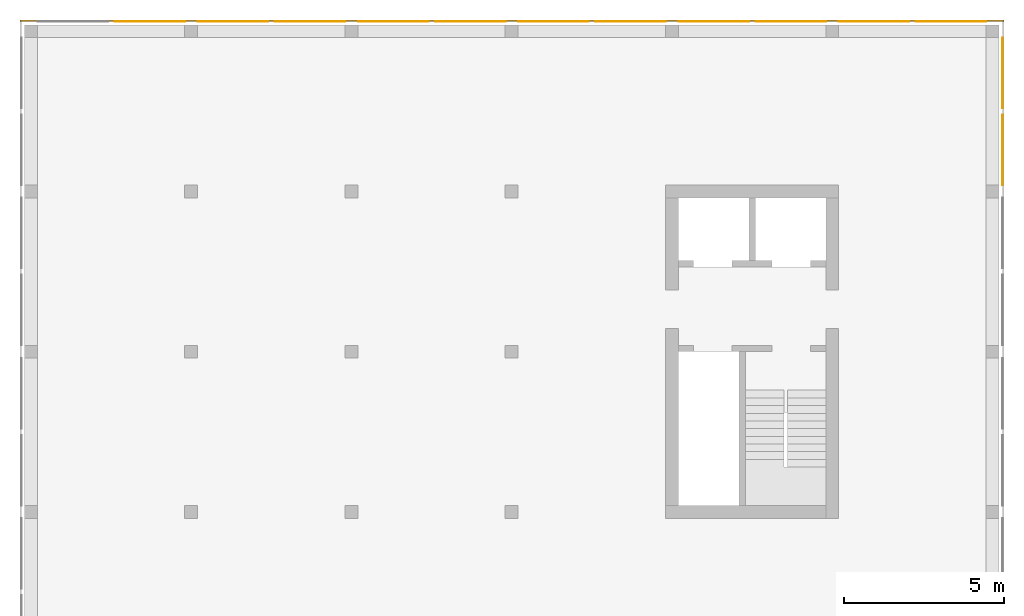
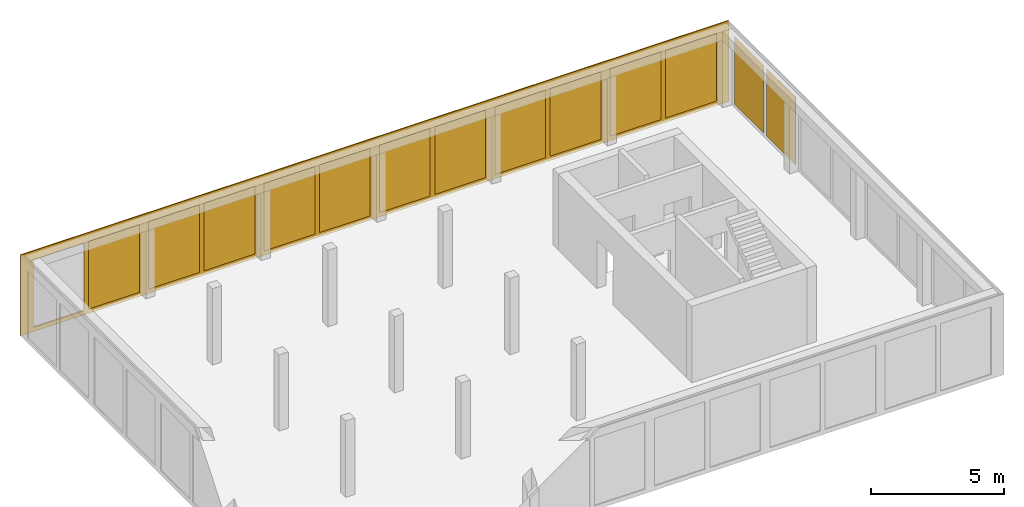
# One storey, part 4 of 4: 14 curtain walls.
"""IFC2X3 building model written with IfcOpenShell, lengths in metres."""

from ifc_helpers import new_model, entity, si_unit, converted_unit, frame, origin, place, context, subcontext, project, spatial, faceted_brep, material, element, save


model = new_model("IFC2X3")

# Units and contexts
model_context = context("Model", 3, precision=1e-05, world=origin())
body_context = subcontext(model_context, "Body", "Model", "MODEL_VIEW")
ifc_project = project(units=[si_unit("LENGTHUNIT", "METRE"), si_unit("AREAUNIT", "SQUARE_METRE"), si_unit("VOLUMEUNIT", "CUBIC_METRE"), si_unit("MASSUNIT", "GRAM", prefix="KILO"), converted_unit("PLANEANGLEUNIT", "DEGREE", entity("IfcPlaneAngleMeasure", 0.0174532925199433), si_unit("PLANEANGLEUNIT", "RADIAN"), dimensions=[0, 0, 0, 0, 0, 0, 0])], contexts=[model_context])

# Site, building, storey
site_placement = place(None, origin())
site = spatial("IfcSite", under=ifc_project, at=site_placement, CompositionType="ELEMENT")
building_placement = place(site_placement, origin())
building = spatial("IfcBuilding", under=site, at=building_placement, CompositionType="ELEMENT")
storey_placement = place(building_placement, frame((0.0, 0.0, 4.9)))
storey = spatial("IfcBuildingStorey", under=building, at=storey_placement, Name="1. Obergeschoss", CompositionType="ELEMENT", Elevation=4.9)

# Curtain walls
ifc_material_1 = material(Name="ALU")
curtain_wall_1_placement = place(storey_placement, frame((-0.139330706017223, 20.5, -0.2)))
element("IfcCurtainWall", 1, at=curtain_wall_1_placement, inside=storey, material=ifc_material_1, Name="Profil SN standard", context=body_context, shape_type="Brep", body=[
    faceted_brep([(0.0, 0.05, 3.7), (30.7, 0.05, 3.7), (30.7, 0.0, 3.7), (0.0, 0.0, 3.7), (30.7, 0.05, 0.0), (0.0, 0.05, 0.0), (0.0, 0.0, 0.0), (30.7, 0.0, 0.0), (27.95, 0.0, 0.2), (27.95, 0.0, 3.3), (27.95, 0.05, 3.3), (27.95, 0.05, 0.2), (27.75, 0.05, 0.2), (27.75, 0.05, 3.3), (27.75, 0.0, 3.3), (27.75, 0.0, 0.2), (22.95, 0.0, 0.2), (22.95, 0.0, 3.3), (22.95, 0.05, 3.3), (22.95, 0.05, 0.2), (22.75, 0.05, 0.2), (22.75, 0.05, 3.3), (22.75, 0.0, 3.3), (22.75, 0.0, 0.2), (17.75, 0.05, 0.200000000000001), (17.75, 0.05, 3.3), (17.75, 0.0, 3.3), (17.75, 0.0, 0.200000000000001), (17.95, 0.0, 0.200000000000001), (17.95, 0.0, 3.3), (17.95, 0.05, 3.3), (17.95, 0.05, 0.200000000000001), (25.15, 0.0, 0.200000000000001), (25.15, 0.05, 0.200000000000001), (25.15, 0.05, 3.3), (25.15, 0.0, 3.3), (25.55, 0.05, 0.200000000000001), (25.55, 0.0, 0.200000000000001), (25.55, 0.0, 3.3), (25.55, 0.05, 3.3), (20.15, 0.0, 0.200000000000001), (20.15, 0.05, 0.200000000000001), (20.15, 0.05, 3.3), (20.15, 0.0, 3.3), (20.55, 0.05, 0.200000000000001), (20.55, 0.0, 0.200000000000001), (20.55, 0.0, 3.3), (20.55, 0.05, 3.3), (30.15, 0.0, 0.200000000000001), (30.15, 0.05, 0.200000000000001), (30.15, 0.05, 3.3), (30.15, 0.0, 3.3), (2.75, 0.05, 0.200000000000001), (2.75, 0.05, 3.3), (2.75, 0.0, 3.3), (2.75, 0.0, 0.200000000000001), (2.95, 0.0, 0.200000000000001), (2.95, 0.0, 3.3), (2.95, 0.05, 3.3), (2.95, 0.05, 0.200000000000001), (12.75, 0.05, 0.200000000000001), (12.75, 0.05, 3.3), (12.75, 0.0, 3.3), (12.75, 0.0, 0.200000000000001), (12.95, 0.0, 0.200000000000001), (12.95, 0.0, 3.3), (12.95, 0.05, 3.3), (12.95, 0.05, 0.200000000000001), (7.75, 0.05, 0.200000000000001), (7.75, 0.05, 3.3), (7.75, 0.0, 3.3), (7.75, 0.0, 0.200000000000001), (7.95, 0.0, 0.200000000000001), (7.95, 0.0, 3.3), (7.95, 0.05, 3.3), (7.95, 0.05, 0.200000000000001), (15.55, 0.0, 0.200000000000001), (15.55, 0.05, 0.200000000000001), (15.55, 0.0, 3.3), (15.55, 0.05, 3.3), (10.55, 0.05, 3.3), (10.55, 0.0, 3.3), (15.15, 0.0, 3.3), (15.15, 0.05, 3.3), (15.15, 0.0, 0.200000000000001), (15.15, 0.05, 0.200000000000001), (10.55, 0.0, 0.200000000000001), (10.55, 0.05, 0.200000000000001), (0.550000000000002, 0.05, 3.3), (0.550000000000002, 0.0, 3.3), (5.15, 0.0, 3.3), (5.15, 0.05, 3.3), (5.15, 0.0, 0.200000000000001), (5.15, 0.05, 0.200000000000001), (0.550000000000002, 0.0, 0.2), (0.550000000000002, 0.05, 0.2), (5.55, 0.05, 0.200000000000001), (5.55, 0.0, 0.200000000000001), (5.55, 0.0, 3.3), (5.55, 0.05, 3.3), (10.15, 0.0, 3.3), (10.15, 0.05, 3.3), (10.15, 0.0, 0.200000000000001), (10.15, 0.05, 0.200000000000001)], [[[0, 1, 2, 3]], [[4, 5, 6, 7]], [[7, 2, 1, 4]], [[5, 0, 3, 6]], [[8, 9, 10, 11]], [[12, 13, 14, 15]], [[16, 17, 18, 19]], [[20, 21, 22, 23]], [[24, 25, 26, 27]], [[28, 29, 30, 31]], [[32, 33, 34, 35]], [[36, 37, 38, 39]], [[40, 41, 42, 43]], [[44, 45, 46, 47]], [[48, 49, 50, 51]], [[52, 53, 54, 55]], [[56, 57, 58, 59]], [[60, 61, 62, 63]], [[64, 65, 66, 67]], [[68, 69, 70, 71]], [[72, 73, 74, 75]], [[31, 41, 40, 28]], [[27, 76, 77, 24]], [[77, 76, 78, 79]], [[25, 79, 78, 26]], [[29, 43, 42, 30]], [[61, 80, 81, 62]], [[65, 82, 83, 66]], [[84, 85, 83, 82]], [[67, 85, 84, 64]], [[63, 86, 87, 60]], [[87, 86, 81, 80]], [[53, 88, 89, 54]], [[57, 90, 91, 58]], [[92, 93, 91, 90]], [[59, 93, 92, 56]], [[55, 94, 95, 52]], [[95, 94, 89, 88]], [[96, 97, 98, 99]], [[69, 99, 98, 70]], [[73, 100, 101, 74]], [[102, 103, 101, 100]], [[75, 103, 102, 72]], [[71, 97, 96, 68]], [[19, 33, 32, 16]], [[23, 45, 44, 20]], [[21, 47, 46, 22]], [[17, 35, 34, 18]], [[11, 49, 48, 8]], [[15, 37, 36, 12]], [[13, 39, 38, 14]], [[9, 51, 50, 10]], [[2, 7, 6, 3], [102, 100, 73, 72], [92, 90, 57, 56], [84, 82, 65, 64], [70, 98, 97, 71], [62, 81, 86, 63], [29, 28, 40, 43], [54, 89, 94, 55], [26, 78, 76, 27], [16, 32, 35, 17], [46, 45, 23, 22], [8, 48, 51, 9], [38, 37, 15, 14]], [[0, 5, 4, 1], [95, 88, 53, 52], [96, 99, 69, 68], [87, 80, 61, 60], [74, 101, 103, 75], [66, 83, 85, 67], [58, 91, 93, 59], [77, 79, 25, 24], [30, 42, 41, 31], [20, 44, 47, 21], [34, 33, 19, 18], [12, 36, 39, 13], [50, 49, 11, 10]]], orient=[[False], [False], [False], [False], [False], [False], [False], [False], [False], [False], [False], [False], [False], [False], [False], [False], [False], [False], [False], [False], [False], [False], [False], [False], [False], [False], [False], [False], [False], [False], [False], [False], [False], [False], [False], [False], [False], [False], [False], [False], [False], [False], [False], [False], [False], [False], [False], [False], [False], [False], [False], [False], [False, False, False, False, False, False, False, False, False, False, False, False, False], [False, False, False, False, False, False, False, False, False, False, False, False, False]]),
])
ifc_material_2 = material(Name="VSG")
curtain_wall_2_placement = place(storey_placement, frame((2.81066929398278, 20.5, 0.0)))
element("IfcCurtainWall", 2, at=curtain_wall_2_placement, inside=storey, material=ifc_material_2, Name="standard", context=body_context, shape_type="Brep", body=[
    faceted_brep([(2.2, 0.0, 0.0), (2.2, 0.0, 3.1), (2.2, 0.005, 3.1), (2.2, 0.005, 0.0), (0.0, 0.005, 3.1), (0.0, 0.005, 0.0), (0.0, 0.0, 3.1), (0.0, 0.0, 0.0)], [[[0, 1, 2, 3]], [[3, 2, 4, 5]], [[5, 4, 6, 7]], [[7, 6, 1, 0]], [[6, 4, 2, 1]], [[0, 3, 5, 7]]], orient=[[False], [False], [False], [False], [False], [False]]),
])
ifc_material_3 = material(Name="VSG")
curtain_wall_3_placement = place(storey_placement, frame((5.41066929398277, 20.5, 0.0)))
element("IfcCurtainWall", 3, at=curtain_wall_3_placement, inside=storey, material=ifc_material_3, Name="standard", context=body_context, shape_type="Brep", body=[
    faceted_brep([(2.2, 0.0, 0.0), (2.2, 0.0, 3.1), (2.2, 0.005, 3.1), (2.2, 0.005, 0.0), (0.0, 0.005, 3.1), (0.0, 0.005, 0.0), (0.0, 0.0, 3.1), (0.0, 0.0, 0.0)], [[[0, 1, 2, 3]], [[3, 2, 4, 5]], [[5, 4, 6, 7]], [[7, 6, 1, 0]], [[6, 4, 2, 1]], [[0, 3, 5, 7]]], orient=[[False], [False], [False], [False], [False], [False]]),
])
ifc_material_4 = material(Name="VSG")
curtain_wall_4_placement = place(storey_placement, frame((7.81066929398278, 20.5, 0.0)))
element("IfcCurtainWall", 4, at=curtain_wall_4_placement, inside=storey, material=ifc_material_4, Name="standard", context=body_context, shape_type="Brep", body=[
    faceted_brep([(2.2, 0.0, 0.0), (2.2, 0.0, 3.1), (2.2, 0.005, 3.1), (2.2, 0.005, 0.0), (0.0, 0.005, 3.1), (0.0, 0.005, 0.0), (0.0, 0.0, 3.1), (0.0, 0.0, 0.0)], [[[0, 1, 2, 3]], [[3, 2, 4, 5]], [[5, 4, 6, 7]], [[7, 6, 1, 0]], [[6, 4, 2, 1]], [[0, 3, 5, 7]]], orient=[[False], [False], [False], [False], [False], [False]]),
])
ifc_material_5 = material(Name="VSG")
curtain_wall_5_placement = place(storey_placement, frame((10.4106692939828, 20.5, 0.0)))
element("IfcCurtainWall", 5, at=curtain_wall_5_placement, inside=storey, material=ifc_material_5, Name="standard", context=body_context, shape_type="Brep", body=[
    faceted_brep([(2.2, 0.0, 0.0), (2.2, 0.0, 3.1), (2.2, 0.005, 3.1), (2.2, 0.005, 0.0), (0.0, 0.005, 3.1), (0.0, 0.005, 0.0), (0.0, 0.0, 3.1), (0.0, 0.0, 0.0)], [[[0, 1, 2, 3]], [[3, 2, 4, 5]], [[5, 4, 6, 7]], [[7, 6, 1, 0]], [[6, 4, 2, 1]], [[0, 3, 5, 7]]], orient=[[False], [False], [False], [False], [False], [False]]),
])
ifc_material_6 = material(Name="VSG")
curtain_wall_6_placement = place(storey_placement, frame((12.8106692939828, 20.5, 0.0)))
element("IfcCurtainWall", 6, at=curtain_wall_6_placement, inside=storey, material=ifc_material_6, Name="standard", context=body_context, shape_type="Brep", body=[
    faceted_brep([(2.2, 0.0, 0.0), (2.2, 0.0, 3.1), (2.2, 0.005, 3.1), (2.2, 0.005, 0.0), (0.0, 0.005, 3.1), (0.0, 0.005, 0.0), (0.0, 0.0, 3.1), (0.0, 0.0, 0.0)], [[[0, 1, 2, 3]], [[3, 2, 4, 5]], [[5, 4, 6, 7]], [[7, 6, 1, 0]], [[6, 4, 2, 1]], [[0, 3, 5, 7]]], orient=[[False], [False], [False], [False], [False], [False]]),
])
ifc_material_7 = material(Name="VSG")
curtain_wall_7_placement = place(storey_placement, frame((15.4106692939828, 20.5, 0.0)))
element("IfcCurtainWall", 7, at=curtain_wall_7_placement, inside=storey, material=ifc_material_7, Name="standard", context=body_context, shape_type="Brep", body=[
    faceted_brep([(2.20000000000001, 0.0, 0.0), (2.20000000000001, 0.0, 3.1), (2.20000000000001, 0.005, 3.1), (2.20000000000001, 0.005, 0.0), (1.81898940354586e-15, 0.005, 3.1), (1.81898940354586e-15, 0.005, 0.0), (1.81898940354586e-15, 0.0, 3.1), (1.81898940354586e-15, 0.0, 0.0)], [[[0, 1, 2, 3]], [[3, 2, 4, 5]], [[5, 4, 6, 7]], [[7, 6, 1, 0]], [[6, 4, 2, 1]], [[0, 3, 5, 7]]], orient=[[False], [False], [False], [False], [False], [False]]),
])
ifc_material_8 = material(Name="VSG")
curtain_wall_8_placement = place(storey_placement, frame((17.8106692939828, 20.5, 0.0)))
element("IfcCurtainWall", 8, at=curtain_wall_8_placement, inside=storey, material=ifc_material_8, Name="standard", context=body_context, shape_type="Brep", body=[
    faceted_brep([(2.2, 0.0, 0.0), (2.2, 0.0, 3.1), (2.2, 0.005, 3.1), (2.2, 0.005, 0.0), (0.0, 0.005, 3.1), (0.0, 0.005, 0.0), (0.0, 0.0, 3.1), (0.0, 0.0, 0.0)], [[[0, 1, 2, 3]], [[3, 2, 4, 5]], [[5, 4, 6, 7]], [[7, 6, 1, 0]], [[6, 4, 2, 1]], [[0, 3, 5, 7]]], orient=[[False], [False], [False], [False], [False], [False]]),
])
ifc_material_9 = material(Name="VSG")
curtain_wall_9_placement = place(storey_placement, frame((20.4106692939828, 20.5, 0.0)))
element("IfcCurtainWall", 9, at=curtain_wall_9_placement, inside=storey, material=ifc_material_9, Name="standard", context=body_context, shape_type="Brep", body=[
    faceted_brep([(2.2, 0.0, 0.0), (2.2, 0.0, 3.1), (2.2, 0.005, 3.1), (2.2, 0.005, 0.0), (0.0, 0.005, 3.1), (0.0, 0.005, 0.0), (0.0, 0.0, 3.1), (0.0, 0.0, 0.0)], [[[0, 1, 2, 3]], [[3, 2, 4, 5]], [[5, 4, 6, 7]], [[7, 6, 1, 0]], [[6, 4, 2, 1]], [[0, 3, 5, 7]]], orient=[[False], [False], [False], [False], [False], [False]]),
])
ifc_material_10 = material(Name="VSG")
curtain_wall_10_placement = place(storey_placement, frame((22.8106692939828, 20.5, 0.0)))
element("IfcCurtainWall", 10, at=curtain_wall_10_placement, inside=storey, material=ifc_material_10, Name="standard", context=body_context, shape_type="Brep", body=[
    faceted_brep([(2.2, 0.0, 0.0), (2.2, 0.0, 3.1), (2.2, 0.005, 3.1), (2.2, 0.005, 0.0), (0.0, 0.005, 3.1), (0.0, 0.005, 0.0), (0.0, 0.0, 3.1), (0.0, 0.0, 0.0)], [[[0, 1, 2, 3]], [[3, 2, 4, 5]], [[5, 4, 6, 7]], [[7, 6, 1, 0]], [[6, 4, 2, 1]], [[0, 3, 5, 7]]], orient=[[False], [False], [False], [False], [False], [False]]),
])
ifc_material_11 = material(Name="VSG")
curtain_wall_11_placement = place(storey_placement, frame((25.4106692939828, 20.5, 0.0)))
element("IfcCurtainWall", 11, at=curtain_wall_11_placement, inside=storey, material=ifc_material_11, Name="standard", context=body_context, shape_type="Brep", body=[
    faceted_brep([(2.2, 0.0, 0.0), (2.2, 0.0, 3.1), (2.2, 0.005, 3.1), (2.2, 0.005, 0.0), (0.0, 0.005, 3.1), (0.0, 0.005, 0.0), (0.0, 0.0, 3.1), (0.0, 0.0, 0.0)], [[[0, 1, 2, 3]], [[3, 2, 4, 5]], [[5, 4, 6, 7]], [[7, 6, 1, 0]], [[6, 4, 2, 1]], [[0, 3, 5, 7]]], orient=[[False], [False], [False], [False], [False], [False]]),
])
ifc_material_12 = material(Name="VSG")
curtain_wall_12_placement = place(storey_placement, frame((27.8106692939828, 20.5, 0.0)))
element("IfcCurtainWall", 12, at=curtain_wall_12_placement, inside=storey, material=ifc_material_12, Name="standard", context=body_context, shape_type="Brep", body=[
    faceted_brep([(2.2, 0.0, 0.0), (2.2, 0.0, 3.1), (2.2, 0.005, 3.1), (2.2, 0.005, 0.0), (0.0, 0.005, 3.1), (0.0, 0.005, 0.0), (0.0, 0.0, 3.1), (0.0, 0.0, 0.0)], [[[0, 1, 2, 3]], [[3, 2, 4, 5]], [[5, 4, 6, 7]], [[7, 6, 1, 0]], [[6, 4, 2, 1]], [[0, 3, 5, 7]]], orient=[[False], [False], [False], [False], [False], [False]]),
])
ifc_material_13 = material(Name="VSG")
curtain_wall_13_placement = place(storey_placement, frame((30.5106692939828, 17.8, 0.0)))
element("IfcCurtainWall", 13, at=curtain_wall_13_placement, inside=storey, material=ifc_material_13, Name="standard", context=body_context, shape_type="Brep", body=[
    faceted_brep([(0.0, -3.63797880709171e-15, 0.0), (0.0, -3.63797880709171e-15, 3.1), (0.005, -3.63797880709171e-15, 3.1), (0.005, -3.63797880709171e-15, 0.0), (0.005, 2.2, 3.1), (0.005, 2.2, 0.0), (0.0, 2.2, 3.1), (0.0, 2.2, 0.0)], [[[0, 1, 2, 3]], [[3, 2, 4, 5]], [[5, 4, 6, 7]], [[7, 6, 1, 0]], [[6, 4, 2, 1]], [[0, 3, 5, 7]]], orient=[[False], [False], [False], [False], [False], [False]]),
])
ifc_material_14 = material(Name="VSG")
curtain_wall_14_placement = place(storey_placement, frame((30.5106692939828, 15.4, 0.0)))
element("IfcCurtainWall", 14, at=curtain_wall_14_placement, inside=storey, material=ifc_material_14, Name="standard", context=body_context, shape_type="Brep", body=[
    faceted_brep([(0.0, -1.81898940354586e-15, 0.0), (0.0, -1.81898940354586e-15, 3.1), (0.005, -1.81898940354586e-15, 3.1), (0.005, -1.81898940354586e-15, 0.0), (0.005, 2.2, 3.1), (0.005, 2.2, 0.0), (0.0, 2.2, 3.1), (0.0, 2.2, 0.0)], [[[0, 1, 2, 3]], [[3, 2, 4, 5]], [[5, 4, 6, 7]], [[7, 6, 1, 0]], [[6, 4, 2, 1]], [[0, 3, 5, 7]]], orient=[[False], [False], [False], [False], [False], [False]]),
])

save(model, "model.ifc")
